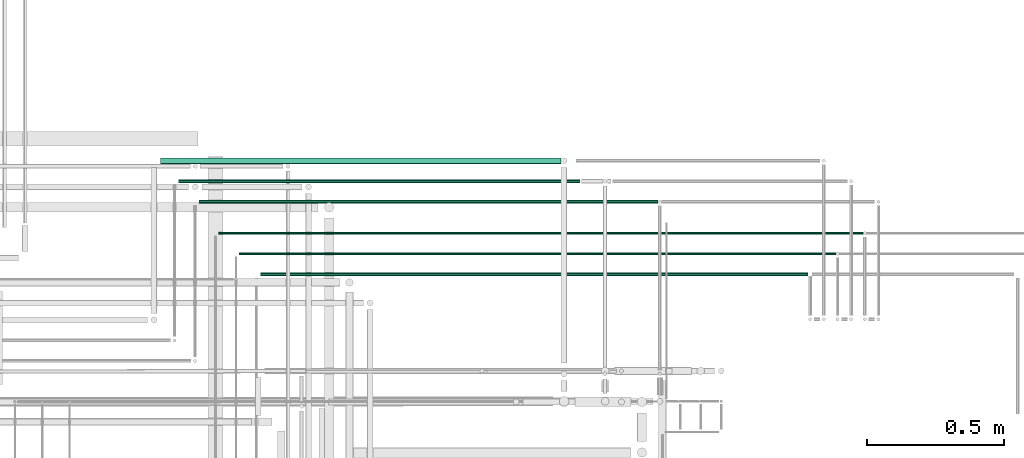
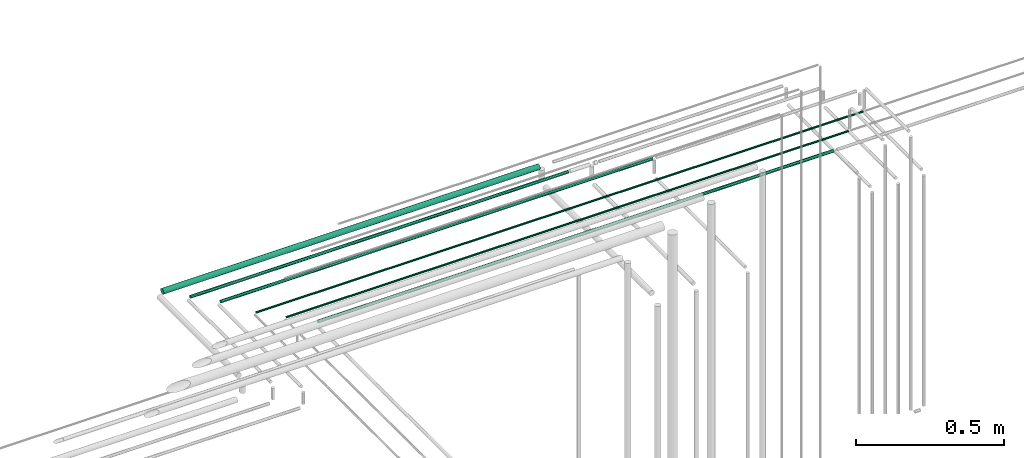
# One storey, part 97 of 331: 6 flow segments.
"""IFC2X3 building model written with IfcOpenShell, lengths in millimetres."""

import ifcopenshell
import ifcopenshell.guid

model = None  # the IFC model being written
_history = None  # IfcOwnerHistory: only IFC2X3 demands one
_inside = {}  # id of a spatial element -> (the spatial element, [elements in it])
_under = {}  # id of a project, library or spatial element -> (it, [spatial elements below it])
_declared = {}  # id of a project -> (the project, [libraries it declares])
_typed = {}  # id of a type object -> (the type object, [elements of that type])
_made_of = {}  # id of a material, layer set ... -> (it, [elements and type objects made of it])


def new_model(schema):
    """Start an empty IFC model of exactly this schema.

    Asked for "IFC4X3", IfcOpenShell would pick the latest addendum, in which some entities
    have other attributes; the version numbers below select the first issue.
    IFC2X3 requires an IfcOwnerHistory on every rooted entity: one is made here for all.
    """
    global model, _history
    if schema == "IFC4X3":
        model = ifcopenshell.file(schema_version=(4, 3, 0, 0))
    else:
        model = ifcopenshell.file(schema=schema)
    _inside.clear()
    _under.clear()
    _declared.clear()
    _typed.clear()
    _made_of.clear()
    _history = None
    if model.schema == "IFC2X3":
        org = make("IfcOrganization", Name="unknown")
        user = make(
            "IfcPersonAndOrganization",
            ThePerson=make("IfcPerson", FamilyName="unknown"),
            TheOrganization=org,
        )
        app = make(
            "IfcApplication",
            ApplicationDeveloper=org,
            Version="unknown",
            ApplicationFullName="unknown",
            ApplicationIdentifier="unknown",
        )
        _history = make(
            "IfcOwnerHistory",
            OwningUser=user,
            OwningApplication=app,
            ChangeAction="ADDED",
            CreationDate=0,
        )
    return model


def make(cls, **values):
    """One entity of the class cls with the attributes given. An attribute that is None is left unset."""
    return model.create_entity(
        cls, **{name: value for name, value in values.items() if value is not None}
    )


def entity(cls, *values):
    """Any entity or typed value of the class cls, its attributes in the order of the schema. None: left unset."""
    e = model.create_entity(cls)
    for i, value in enumerate(values):
        if value is not None:
            e[i] = value
    return e


def rooted(cls, **values):
    """An entity with a GlobalId (a new one), such as an element, a storey or a relation."""
    return make(cls, GlobalId=ifcopenshell.guid.new(), OwnerHistory=_history, **values)


def si_unit(unit_type, name, prefix=None):
    """IfcSIUnit, for example si_unit("LENGTHUNIT", "METRE", prefix="MILLI")."""
    return make("IfcSIUnit", UnitType=unit_type, Prefix=prefix, Name=name)


def converted_unit(unit_type, name, factor, base, dimensions=None, offset=None):
    """IfcConversionBasedUnit, such as the inch: factor (a typed value) times the base unit."""
    return make(
        "IfcConversionBasedUnit"
        if offset is None
        else "IfcConversionBasedUnitWithOffset",
        ConversionOffset=offset,
        Dimensions=None
        if dimensions is None
        else entity("IfcDimensionalExponents", *dimensions),
        UnitType=unit_type,
        Name=name,
        ConversionFactor=make(
            "IfcMeasureWithUnit", ValueComponent=factor, UnitComponent=base
        ),
    )


def derived_unit(unit_type, elements):
    """IfcDerivedUnit: a product of units, each with its exponent."""
    return make(
        "IfcDerivedUnit",
        Elements=[
            make("IfcDerivedUnitElement", Unit=unit, Exponent=power)
            for unit, power in elements
        ],
        UnitType=unit_type,
    )


def assignment(units):
    """IfcUnitAssignment: the units of a project."""
    return None if units is None else make("IfcUnitAssignment", Units=units)


def point(xyz):
    """IfcCartesianPoint."""
    return None if xyz is None else make("IfcCartesianPoint", Coordinates=xyz)


def direction(xyz):
    """IfcDirection."""
    return None if xyz is None else make("IfcDirection", DirectionRatios=xyz)


def frame(location, z_axis=None, x_axis=None):
    """IfcAxis2Placement3D, a coordinate frame: its origin and axes. An axis left out is left unset."""
    return make(
        "IfcAxis2Placement3D",
        Location=point(location),
        Axis=direction(z_axis),
        RefDirection=direction(x_axis),
    )


def frame_2d(location, x_axis=None):
    """IfcAxis2Placement2D, a coordinate frame in the plane: its origin and x axis."""
    return make(
        "IfcAxis2Placement2D", Location=point(location), RefDirection=direction(x_axis)
    )


def origin():
    """The frame at (0, 0, 0) with its axes left unset."""
    return frame((0.0, 0.0, 0.0))


def place(relative_to, where):
    """IfcLocalPlacement: puts the frame where relative to a parent placement (None: the world)."""
    return make(
        "IfcLocalPlacement", PlacementRelTo=relative_to, RelativePlacement=where
    )


def context(
    kind, dimensions, precision=None, world=None, true_north=None, identifier=None
):
    """IfcGeometricRepresentationContext, for example the 3D "Model" context."""
    return make(
        "IfcGeometricRepresentationContext",
        ContextIdentifier=identifier,
        ContextType=kind,
        CoordinateSpaceDimension=dimensions,
        Precision=precision,
        WorldCoordinateSystem=world,
        TrueNorth=true_north,
    )


def subcontext(parent, identifier, kind, view, scale=None):
    """IfcGeometricRepresentationSubContext, for example "Body" below "Model"."""
    return make(
        "IfcGeometricRepresentationSubContext",
        ContextIdentifier=identifier,
        ContextType=kind,
        ParentContext=parent,
        TargetScale=scale,
        TargetView=view,
    )


def project(units=None, contexts=None):
    """IfcProject with its units and contexts."""
    return rooted(
        "IfcProject",
        Name="project",
        RepresentationContexts=contexts,
        UnitsInContext=assignment(units),
    )


def spatial(cls, under=None, at=None, **own):
    """A site, building, storey or space (cls), placed at a placement, below another one or the project."""
    s = rooted(cls, ObjectPlacement=at, **own)
    if under is not None:
        _under.setdefault(under.id(), (under, []))[1].append(s)
    return s


def profile(cls, at=None, kind="AREA", **sizes):
    """A parametric profile (cls). Its sizes go by their IFC names, for example OverallWidth=200.0."""
    return make(cls, ProfileType=kind, Position=at, **sizes)


def circle(**sizes):
    """IfcCircleProfileDef."""
    return profile("IfcCircleProfileDef", **sizes)


def extrude(swept, where, along, depth):
    """IfcExtrudedAreaSolid: the profile swept, set in the frame where, extruded along a direction by depth."""
    return make(
        "IfcExtrudedAreaSolid",
        SweptArea=swept,
        Position=where,
        ExtrudedDirection=direction(along),
        Depth=depth,
    )


def shape(context_of_items, identifier, shape_type, items):
    """IfcShapeRepresentation: the items that make up one representation, for example the "Body"."""
    return make(
        "IfcShapeRepresentation",
        ContextOfItems=context_of_items,
        RepresentationIdentifier=identifier,
        RepresentationType=shape_type,
        Items=items,
    )


def made_of(thing, what):
    """Note that an element or type object is made of a material, layer set ...; save() writes the relation."""
    if what is not None:
        _made_of.setdefault(what.id(), (what, []))[1].append(thing)
    return thing


def type_object(cls, material=None, **own):
    """A type object (cls), such as IfcWallType, which elements share."""
    return made_of(rooted(cls, **own), material)


def element(
    cls,
    number,
    at=None,
    inside=None,
    cuts=None,
    type_object=None,
    material=None,
    context=None,
    identifier="Body",
    shape_type=None,
    held_by="IfcProductDefinitionShape",
    body=None,
    shapes=None,
    **own,
):
    """One element of the class cls, such as IfcWall. Its Tag is "e" and its number.

    at: its placement. inside: the storey or other place that contains it. cuts: it is an
    opening in that element (IfcRelVoidsElement). A single representation is given by context,
    identifier, shape_type and body (its items); several are given by shapes. held_by: the class
    of the entity that holds the representations. save() writes the other relations.
    """
    e = rooted(cls, Tag="e%d" % number, ObjectPlacement=at, **own)
    if body is not None:
        shapes = [shape(context, identifier, shape_type, body)]
    if shapes is not None:
        e.Representation = make(held_by, Representations=shapes)
    if inside is not None:
        _inside.setdefault(inside.id(), (inside, []))[1].append(e)
    if cuts is not None:
        rooted(
            "IfcRelVoidsElement", RelatingBuildingElement=cuts, RelatedOpeningElement=e
        )
    if type_object is not None:
        _typed.setdefault(type_object.id(), (type_object, []))[1].append(e)
    return made_of(e, material)


def aggregate(whole, parts):
    """IfcRelAggregates: a whole, such as a stair, and the parts it consists of."""
    return rooted("IfcRelAggregates", RelatingObject=whole, RelatedObjects=parts)


def save(model, path):
    """Write the relations noted so far, then the file.

    IfcRelAggregates (storeys below a building ...), IfcRelContainedInSpatialStructure (elements
    in a storey), IfcRelDefinesByType, IfcRelAssociatesMaterial and IfcRelDeclares: one each for
    every whole, place, type object, material and project.
    """
    for whole, parts in _under.values():
        aggregate(whole, parts)
    for where, things in _inside.values():
        rooted(
            "IfcRelContainedInSpatialStructure",
            RelatedElements=things,
            RelatingStructure=where,
        )
    for kind, things in _typed.values():
        rooted("IfcRelDefinesByType", RelatedObjects=things, RelatingType=kind)
    for what, things in _made_of.values():
        rooted("IfcRelAssociatesMaterial", RelatedObjects=things, RelatingMaterial=what)
    for by, libraries in _declared.values():
        rooted("IfcRelDeclares", RelatingContext=by, RelatedDefinitions=libraries)
    model.write(path)


model = new_model("IFC2X3")

# Units and contexts
model_context = context("Model", 3, precision=0.01, world=origin(), true_north=direction((6.12303176911189e-17, 1.0)))
body_context = subcontext(model_context, "Body", "Model", "MODEL_VIEW")
ifc_project = project(units=[si_unit("LENGTHUNIT", "METRE", prefix="MILLI"), si_unit("AREAUNIT", "SQUARE_METRE"), si_unit("VOLUMEUNIT", "CUBIC_METRE"), converted_unit("PLANEANGLEUNIT", "DEGREE", entity("IfcRatioMeasure", 0.0174532925199433), si_unit("PLANEANGLEUNIT", "RADIAN"), dimensions=[0, 0, 0, 0, 0, 0, 0]), si_unit("MASSUNIT", "GRAM", prefix="KILO"), derived_unit("MASSDENSITYUNIT", [(si_unit("MASSUNIT", "GRAM", prefix="KILO"), 1), (si_unit("LENGTHUNIT", "METRE"), -3)]), derived_unit("MOMENTOFINERTIAUNIT", [(si_unit("LENGTHUNIT", "METRE"), 4)]), si_unit("TIMEUNIT", "SECOND"), si_unit("FREQUENCYUNIT", "HERTZ"), si_unit("THERMODYNAMICTEMPERATUREUNIT", "DEGREE_CELSIUS"), derived_unit("THERMALTRANSMITTANCEUNIT", [(si_unit("MASSUNIT", "GRAM", prefix="KILO"), 1), (si_unit("THERMODYNAMICTEMPERATUREUNIT", "KELVIN"), -1), (si_unit("TIMEUNIT", "SECOND"), -3)]), derived_unit("VOLUMETRICFLOWRATEUNIT", [(si_unit("LENGTHUNIT", "METRE"), 3), (si_unit("TIMEUNIT", "SECOND"), -1)]), derived_unit("MASSFLOWRATEUNIT", [(si_unit("MASSUNIT", "GRAM", prefix="KILO"), 1), (si_unit("TIMEUNIT", "SECOND"), -1)]), derived_unit("ROTATIONALFREQUENCYUNIT", [(si_unit("TIMEUNIT", "SECOND"), -1)]), si_unit("ELECTRICCURRENTUNIT", "AMPERE"), si_unit("ELECTRICVOLTAGEUNIT", "VOLT"), si_unit("POWERUNIT", "WATT"), si_unit("FORCEUNIT", "NEWTON", prefix="KILO"), si_unit("ILLUMINANCEUNIT", "LUX"), si_unit("LUMINOUSFLUXUNIT", "LUMEN"), si_unit("LUMINOUSINTENSITYUNIT", "CANDELA"), derived_unit("USERDEFINED", [(si_unit("MASSUNIT", "GRAM", prefix="KILO"), -1), (si_unit("LENGTHUNIT", "METRE"), -2), (si_unit("TIMEUNIT", "SECOND"), 3), (si_unit("LUMINOUSFLUXUNIT", "LUMEN"), 1)]), derived_unit("LINEARVELOCITYUNIT", [(si_unit("LENGTHUNIT", "METRE"), 1), (si_unit("TIMEUNIT", "SECOND"), -1)]), si_unit("PRESSUREUNIT", "PASCAL"), derived_unit("USERDEFINED", [(si_unit("LENGTHUNIT", "METRE"), -2), (si_unit("MASSUNIT", "GRAM", prefix="KILO"), 1), (si_unit("TIMEUNIT", "SECOND"), -2)]), derived_unit("LINEARFORCEUNIT", [(si_unit("MASSUNIT", "GRAM", prefix="KILO"), 1), (si_unit("LENGTHUNIT", "METRE"), 1), (si_unit("TIMEUNIT", "SECOND"), -2), (si_unit("LENGTHUNIT", "METRE"), -1)]), derived_unit("PLANARFORCEUNIT", [(si_unit("MASSUNIT", "GRAM", prefix="KILO"), 1), (si_unit("LENGTHUNIT", "METRE"), 1), (si_unit("TIMEUNIT", "SECOND"), -2), (si_unit("LENGTHUNIT", "METRE"), -2)])], contexts=[model_context])

# Site, building, storey
site_placement = place(None, frame((0.0, -0.00077364408347762, 0.0)))
site = spatial("IfcSite", under=ifc_project, at=site_placement, CompositionType="ELEMENT")
building_placement = place(site_placement, origin())
building = spatial("IfcBuilding", under=site, at=building_placement, CompositionType="ELEMENT")
storey_placement = place(building_placement, origin())
storey = spatial("IfcBuildingStorey", under=building, at=storey_placement, CompositionType="ELEMENT", Elevation=0.0)

# Flow segments
pipe_segment_type = type_object("IfcPipeSegmentType", PredefinedType="NOTDEFINED")
flow_segment_1_placement = place(storey_placement, frame((65249.1052890602, 8607.40479340752, 6742.40472776409)))
element("IfcFlowSegment", 1, at=flow_segment_1_placement, inside=storey, type_object=pipe_segment_type, context=body_context, shape_type="SweptSolid", body=[
    extrude(circle(Radius=6.0, at=frame_2d((-3.24860138789518e-12, -1.08286712929839e-12), x_axis=(1.0, 0.0))), frame((0.0, 7.59527223591887, 7.5952722359167), z_axis=(1.0, 0.0, 0.0), x_axis=(0.0, 1.0, 0.0)), (0.0, 0.0, 1.0), 2004.00659421744),
])
flow_segment_2_placement = place(storey_placement, frame((65170.1052890602, 8684.40479340753, 6744.40472776409)))
element("IfcFlowSegment", 2, at=flow_segment_2_placement, inside=storey, type_object=pipe_segment_type, context=body_context, shape_type="SweptSolid", body=[
    extrude(circle(Radius=4.0, at=frame_2d((-1.08286712929839e-12, 0.0), x_axis=(1.0, 0.0))), frame((0.0, 5.59527223591716, 5.59527223591607), z_axis=(1.0, 0.0, 0.0), x_axis=(0.0, 1.0, 0.0)), (0.0, 0.0, 1.0), 2185.00659421747),
])
flow_segment_3_placement = place(building_placement, frame((64884.1052890601, 9017.40386411664, 6737.40472776408)))
element("IfcFlowSegment", 3, at=flow_segment_3_placement, inside=storey, type_object=pipe_segment_type, context=body_context, shape_type="SweptSolid", body=[
    extrude(circle(Radius=11.0, at=frame_2d((-4.33146851719357e-12, 1.08286712929839e-12), x_axis=(1.0, 0.0))), frame((0.0, 12.5952722359199, 12.5952722359177), z_axis=(1.0, 0.0, 0.0), x_axis=(0.0, 1.0, 0.0)), (0.0, 0.0, 1.0), 1464.0065942175),
])
flow_segment_4_placement = place(building_placement, frame((64949.1052890601, 8947.40386411662, 6742.40472776408)))
element("IfcFlowSegment", 4, at=flow_segment_4_placement, inside=storey, type_object=pipe_segment_type, context=body_context, shape_type="SweptSolid", body=[
    extrude(circle(Radius=6.0, at=frame_2d((0.0, -1.08286712929839e-12), x_axis=(1.0, 0.0))), frame((0.0, 7.59527223594161, 7.59527223591454), z_axis=(1.0, 0.0, 0.0), x_axis=(0.0, -1.0, 0.0)), (0.0, 0.0, 1.0), 1469.59939795501),
])
flow_segment_5_placement = place(building_placement, frame((65024.1052890602, 8872.40386411662, 6742.40472776408)))
element("IfcFlowSegment", 5, at=flow_segment_5_placement, inside=storey, type_object=pipe_segment_type, context=body_context, shape_type="SweptSolid", body=[
    extrude(circle(Radius=6.0, at=frame_2d((-9.74580416368554e-12, 0.0), x_axis=(1.0, 0.0))), frame((0.0, 7.59527223592536, 7.59527223591562), z_axis=(1.0, 0.0, 0.0), x_axis=(0.0, 1.0, 0.0)), (0.0, 0.0, 1.0), 1679.0065942175),
])
flow_segment_6_placement = place(storey_placement, frame((65095.1052890601, 8759.40479340752, 6744.40472776408)))
element("IfcFlowSegment", 6, at=flow_segment_6_placement, inside=storey, type_object=pipe_segment_type, context=body_context, shape_type="SweptSolid", body=[
    extrude(circle(Radius=4.0, at=frame_2d((-1.08286712929839e-12, 0.0), x_axis=(1.0, 0.0))), frame((0.0, 5.59527223591499, 5.59527223591607), z_axis=(1.0, 0.0, 0.0), x_axis=(0.0, -1.0, 0.0)), (0.0, 0.0, 1.0), 2360.00659421753),
])

save(model, "model.ifc")
